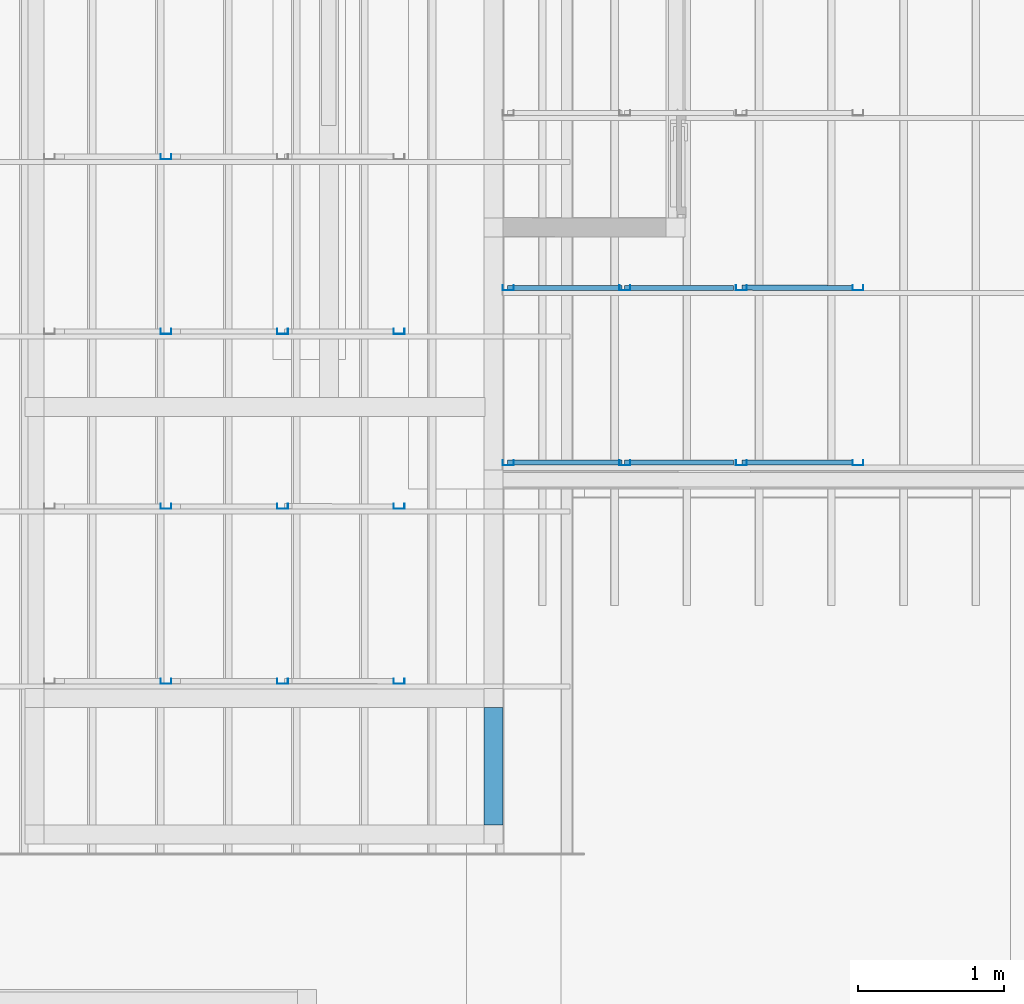
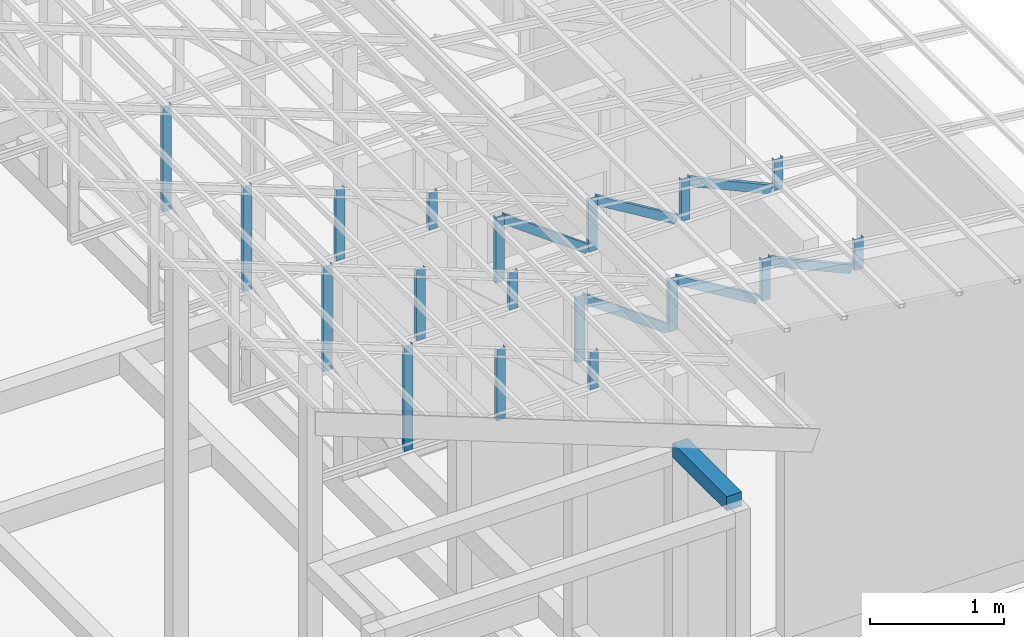
# One storey, part 16 of 22: 24 members, 1 beam, 2 elements without a shape of their own.
"""IFC4 building model written with IfcOpenShell, lengths in millimetres."""

from ifc_helpers import new_model, entity, si_unit, converted_unit, frame, origin_with_axes, origin_2d_with_axis, place, context, subcontext, project, spatial, rectangle, c_section, extrude, material, material_profile, profile_set, profile_usage, type_object, element, aggregate, save


model = new_model("IFC4")

# Units and contexts
model_context = context("Model", 3, precision=1e-05, world=origin_with_axes())
plan_context = context("Plan", 2, precision=1e-05, world=origin_2d_with_axis())
body_context = subcontext(model_context, "Body", "Model", "MODEL_VIEW")
ifc_project = project(units=[si_unit("VOLUMEUNIT", "CUBIC_METRE"), si_unit("LENGTHUNIT", "METRE", prefix="MILLI"), si_unit("AREAUNIT", "SQUARE_METRE"), converted_unit("PLANEANGLEUNIT", "degree", entity("IfcReal", 0.0174532925199433), si_unit("PLANEANGLEUNIT", "RADIAN"), dimensions=[0, 0, 0, 0, 0, 0, 0])], contexts=[model_context, plan_context])

# Site, building, storey
site_placement = place(None, origin_with_axes())
site = spatial("IfcSite", under=ifc_project, at=site_placement)
building_placement = place(site_placement, origin_with_axes())
building = spatial("IfcBuilding", under=site, at=building_placement, Name="2")
storey_placement = place(building_placement, frame((0.0, 0.0, 200.000002980232), z_axis=(0.0, 0.0, 1.0), x_axis=(1.0, 0.0, 0.0)))
storey = spatial("IfcBuildingStorey", under=building, at=storey_placement)

# Beam
ifc_material_1 = material(Name="Concrete")
ifc_material_profile_1 = material_profile(ifc_material_1, rectangle(XDim=130.000015258789, YDim=130.000015258789))
ifc_profile_set_1 = profile_set([ifc_material_profile_1])
ifc_profile_usage_1 = profile_usage(ifc_profile_set_1)
beam_type = type_object("IfcBeamType", Name="Ring", PredefinedType="BEAM", material=ifc_profile_set_1)
beam_placement = place(storey_placement, frame((-3999.99856948853, 4130.00440597534, 3270.00169456005), z_axis=(3.89414367418746e-07, 0.999999999999875, 3.13916473260139e-07), x_axis=(-0.999999999999924, 3.89414367418765e-07, -7.40532613008271e-09)))
element("IfcBeam", 1, at=beam_placement, inside=storey, type_object=beam_type, material=ifc_profile_usage_1, Name="Beam", PredefinedType="BEAM", context=body_context, shape_type="SweptSolid", body=[
    extrude(rectangle(XDim=130.000015258789, YDim=130.000015258789), origin_with_axes(), (0.0, 0.0, 1.0), 804.9960239384),
])

# Assembly, members
assembly_1_placement = place(storey_placement, frame((-1561.45393848419, 6600.0657081604, 3019.63977515697), z_axis=(0.0, 0.0, 1.0), x_axis=(1.0, 0.0, 0.0)))
assembly_1 = element("IfcElementAssembly", 2, at=assembly_1_placement, inside=storey, Name="K1")
ifc_material_2 = material(Name="STEEL")
ifc_material_profile_2 = material_profile(ifc_material_2, c_section(Depth=75.0, Width=35.0, WallThickness=1.0, Girth=1.0, kind="CURVE"))
ifc_profile_set_2 = profile_set([ifc_material_profile_2])
ifc_profile_usage_2 = profile_usage(ifc_profile_set_2, cardinal=9)
member_type = type_object("IfcMemberType", Name="C75", PredefinedType="CHORD", material=ifc_profile_set_2)
member_1_placement = place(assembly_1_placement, frame((-2299.51107501984, -1.06716156005859, 592.46301651001), z_axis=(-8.7422719730052e-08, 3.25841369885875e-07, -0.999999999999943), x_axis=(1.62920684942936e-07, 0.999999999999934, 3.25841369885871e-07)))
member_1 = element("IfcMember", 3, at=member_1_placement, type_object=member_type, material=ifc_profile_usage_2, Name="Member", context=body_context, shape_type="SweptSolid", body=[
    extrude(c_section(Depth=75.0, Width=35.0, WallThickness=1.0, Girth=1.0, kind="CURVE"), frame((17.5, -37.5, 0.0), z_axis=(0.0, 0.0, 1.0), x_axis=(1.0, 0.0, 0.0)), (0.0, 0.0, 1.0), 601.479041515268),
])
ifc_profile_usage_3 = profile_usage(ifc_profile_set_2, cardinal=9)
member_2_placement = place(assembly_1_placement, frame((-1499.51112270355, -1.06716156005859, 479.381561279297), z_axis=(-8.7422719730052e-08, 3.25841369885875e-07, -0.999999999999943), x_axis=(1.62920684942936e-07, 0.999999999999934, 3.25841369885871e-07)))
member_2 = element("IfcMember", 4, at=member_2_placement, type_object=member_type, material=ifc_profile_usage_3, Name="Member", context=body_context, shape_type="SweptSolid", body=[
    extrude(c_section(Depth=75.0, Width=35.0, WallThickness=1.0, Girth=1.0, kind="CURVE"), frame((17.5, -37.5, 0.0), z_axis=(0.0, 0.0, 1.0), x_axis=(1.0, 0.0, 0.0)), (0.0, 0.0, 1.0), 488.397843745656),
])
ifc_profile_usage_4 = profile_usage(ifc_profile_set_2, cardinal=9)
member_3_placement = place(assembly_1_placement, frame((-699.511170387268, -1.06716156005859, 377.824306488037), z_axis=(-8.7422719730052e-08, 3.25841369885875e-07, -0.999999999999943), x_axis=(1.62920684942936e-07, 0.999999999999934, 3.25841369885871e-07)))
member_3 = element("IfcMember", 5, at=member_3_placement, type_object=member_type, material=ifc_profile_usage_4, Name="Member", context=body_context, shape_type="SweptSolid", body=[
    extrude(c_section(Depth=75.0, Width=35.0, WallThickness=1.0, Girth=1.0, kind="CURVE"), frame((17.5, -37.5, 0.0), z_axis=(0.0, 0.0, 1.0), x_axis=(1.0, 0.0, 0.0)), (0.0, 0.0, 1.0), 386.840589191612),
])
ifc_profile_usage_5 = profile_usage(ifc_profile_set_2, cardinal=9)
member_4_placement = place(assembly_1_placement, frame((100.488781929016, -1.06716156005859, 276.402950286865), z_axis=(-8.7422719730052e-08, 3.25841369885875e-07, -0.999999999999943), x_axis=(1.62920684942936e-07, 0.999999999999934, 3.25841369885871e-07)))
member_4 = element("IfcMember", 6, at=member_4_placement, type_object=member_type, material=ifc_profile_usage_5, Name="Member", context=body_context, shape_type="SweptSolid", body=[
    extrude(c_section(Depth=75.0, Width=35.0, WallThickness=1.0, Girth=1.0, kind="CURVE"), frame((17.5, -37.5, 0.0), z_axis=(0.0, 0.0, 1.0), x_axis=(1.0, 0.0, 0.0)), (0.0, 0.0, 1.0), 285.419225275215),
])
ifc_profile_usage_6 = profile_usage(ifc_profile_set_2, cardinal=9)
member_5_placement = place(assembly_1_placement, frame((-702.355027198792, -0.0672340393066406, 368.052959442139), z_axis=(0.912206913056706, -0.00121979383816088, -0.409728031594797), x_axis=(0.00137145876901944, 0.999999056639273, 7.62981516029096e-05)))
member_5 = element("IfcMember", 7, at=member_5_placement, type_object=member_type, material=ifc_profile_usage_6, Name="Member", context=body_context, shape_type="SweptSolid", body=[
    extrude(c_section(Depth=75.0, Width=35.0, WallThickness=1.0, Girth=1.0, kind="CURVE"), frame((17.5, -37.5, 0.0), z_axis=(0.0, 0.0, 1.0), x_axis=(1.0, 0.0, 0.0)), (0.0, 0.0, 1.0), 791.494517196627),
])
ifc_profile_usage_7 = profile_usage(ifc_profile_set_2, cardinal=9)
member_6_placement = place(assembly_1_placement, frame((-1499.51112270355, -1.06716156005859, 479.381561279297), z_axis=(0.855801528545197, -4.23314648434558e-08, -0.517304304775924), x_axis=(7.5497901264043e-08, 0.999999999999996, 4.30689546249139e-08)))
member_6 = element("IfcMember", 8, at=member_6_placement, type_object=member_type, material=ifc_profile_usage_7, Name="Member", context=body_context, shape_type="SweptSolid", body=[
    extrude(c_section(Depth=75.0, Width=35.0, WallThickness=1.0, Girth=1.0, kind="CURVE"), frame((17.5, -37.5, 0.0), z_axis=(0.0, 0.0, 1.0), x_axis=(1.0, 0.0, 0.0)), (0.0, 0.0, 1.0), 826.976096113964),
])
ifc_profile_usage_8 = profile_usage(ifc_profile_set_2, cardinal=9)
member_7_placement = place(assembly_1_placement, frame((-2299.51107501984, -1.06716156005859, 592.46301651001), z_axis=(0.807471586940316, -1.26964538798404e-07, -0.589906464012789), x_axis=(7.54979012640426e-08, 0.999999999999991, -1.1188575399501e-07)))
member_7 = element("IfcMember", 9, at=member_7_placement, type_object=member_type, material=ifc_profile_usage_8, Name="Member", context=body_context, shape_type="SweptSolid", body=[
    extrude(c_section(Depth=75.0, Width=35.0, WallThickness=1.0, Girth=1.0, kind="CURVE"), frame((17.5, -37.5, 0.0), z_axis=(0.0, 0.0, 1.0), x_axis=(1.0, 0.0, 0.0)), (0.0, 0.0, 1.0), 921.685377112707),
])
ifc_profile_usage_9 = profile_usage(ifc_profile_set_2, cardinal=9)
member_8_placement = place(assembly_1_placement, frame((100.488781929016, 1198.93312454224, 276.402950286865), z_axis=(-8.7422719730052e-08, 3.25841369885875e-07, -0.999999999999943), x_axis=(1.62920684942936e-07, 0.999999999999934, 3.25841369885871e-07)))
member_8 = element("IfcMember", 10, at=member_8_placement, type_object=member_type, material=ifc_profile_usage_9, Name="Member", context=body_context, shape_type="SweptSolid", body=[
    extrude(c_section(Depth=75.0, Width=35.0, WallThickness=1.0, Girth=1.0, kind="CURVE"), frame((17.5, -37.5, 0.0), z_axis=(0.0, 0.0, 1.0), x_axis=(1.0, 0.0, 0.0)), (0.0, 0.0, 1.0), 285.419225275215),
])
ifc_profile_usage_10 = profile_usage(ifc_profile_set_2, cardinal=9)
member_9_placement = place(assembly_1_placement, frame((-702.355027198792, 1199.93257522583, 368.052959442139), z_axis=(0.912206913056706, -0.00121979383816088, -0.409728031594797), x_axis=(0.00137145876901944, 0.999999056639273, 7.62981516029096e-05)))
member_9 = element("IfcMember", 11, at=member_9_placement, type_object=member_type, material=ifc_profile_usage_10, Name="Member", context=body_context, shape_type="SweptSolid", body=[
    extrude(c_section(Depth=75.0, Width=35.0, WallThickness=1.0, Girth=1.0, kind="CURVE"), frame((17.5, -37.5, 0.0), z_axis=(0.0, 0.0, 1.0), x_axis=(1.0, 0.0, 0.0)), (0.0, 0.0, 1.0), 791.494517196627),
])
ifc_profile_usage_11 = profile_usage(ifc_profile_set_2, cardinal=9)
member_10_placement = place(assembly_1_placement, frame((-1499.51112270355, 1198.93312454224, 479.381561279297), z_axis=(0.855801528545197, -4.23314648434558e-08, -0.517304304775924), x_axis=(7.5497901264043e-08, 0.999999999999996, 4.30689546249139e-08)))
member_10 = element("IfcMember", 12, at=member_10_placement, type_object=member_type, material=ifc_profile_usage_11, Name="Member", context=body_context, shape_type="SweptSolid", body=[
    extrude(c_section(Depth=75.0, Width=35.0, WallThickness=1.0, Girth=1.0, kind="CURVE"), frame((17.5, -37.5, 0.0), z_axis=(0.0, 0.0, 1.0), x_axis=(1.0, 0.0, 0.0)), (0.0, 0.0, 1.0), 826.976096113964),
])
ifc_profile_usage_12 = profile_usage(ifc_profile_set_2, cardinal=9)
member_11_placement = place(assembly_1_placement, frame((-2299.51107501984, 1198.93312454224, 592.46301651001), z_axis=(-8.7422719730052e-08, 3.25841369885875e-07, -0.999999999999943), x_axis=(1.62920684942936e-07, 0.999999999999934, 3.25841369885871e-07)))
member_11 = element("IfcMember", 13, at=member_11_placement, type_object=member_type, material=ifc_profile_usage_12, Name="Member", context=body_context, shape_type="SweptSolid", body=[
    extrude(c_section(Depth=75.0, Width=35.0, WallThickness=1.0, Girth=1.0, kind="CURVE"), frame((17.5, -37.5, 0.0), z_axis=(0.0, 0.0, 1.0), x_axis=(1.0, 0.0, 0.0)), (0.0, 0.0, 1.0), 601.479041515268),
])
ifc_profile_usage_13 = profile_usage(ifc_profile_set_2, cardinal=9)
member_12_placement = place(assembly_1_placement, frame((-699.511170387268, 1198.93312454224, 377.824306488037), z_axis=(-8.7422719730052e-08, 3.25841369885875e-07, -0.999999999999943), x_axis=(1.62920684942936e-07, 0.999999999999934, 3.25841369885871e-07)))
member_12 = element("IfcMember", 14, at=member_12_placement, type_object=member_type, material=ifc_profile_usage_13, Name="Member", context=body_context, shape_type="SweptSolid", body=[
    extrude(c_section(Depth=75.0, Width=35.0, WallThickness=1.0, Girth=1.0, kind="CURVE"), frame((17.5, -37.5, 0.0), z_axis=(0.0, 0.0, 1.0), x_axis=(1.0, 0.0, 0.0)), (0.0, 0.0, 1.0), 386.840589191612),
])
ifc_profile_usage_14 = profile_usage(ifc_profile_set_2, cardinal=9)
member_13_placement = place(assembly_1_placement, frame((-1499.51112270355, 1198.93312454224, 479.381561279297), z_axis=(-8.7422719730052e-08, 3.25841369885875e-07, -0.999999999999943), x_axis=(1.62920684942936e-07, 0.999999999999934, 3.25841369885871e-07)))
member_13 = element("IfcMember", 15, at=member_13_placement, type_object=member_type, material=ifc_profile_usage_14, Name="Member", context=body_context, shape_type="SweptSolid", body=[
    extrude(c_section(Depth=75.0, Width=35.0, WallThickness=1.0, Girth=1.0, kind="CURVE"), frame((17.5, -37.5, 0.0), z_axis=(0.0, 0.0, 1.0), x_axis=(1.0, 0.0, 0.0)), (0.0, 0.0, 1.0), 488.397843745656),
])
ifc_profile_usage_15 = profile_usage(ifc_profile_set_2, cardinal=9)
member_14_placement = place(assembly_1_placement, frame((-2299.51107501984, 1198.93312454224, 592.46301651001), z_axis=(0.807471586940316, -1.26964538798404e-07, -0.589906464012789), x_axis=(7.54979012640426e-08, 0.999999999999991, -1.1188575399501e-07)))
member_14 = element("IfcMember", 16, at=member_14_placement, type_object=member_type, material=ifc_profile_usage_15, Name="Member", context=body_context, shape_type="SweptSolid", body=[
    extrude(c_section(Depth=75.0, Width=35.0, WallThickness=1.0, Girth=1.0, kind="CURVE"), frame((17.5, -37.5, 0.0), z_axis=(0.0, 0.0, 1.0), x_axis=(1.0, 0.0, 0.0)), (0.0, 0.0, 1.0), 921.685377112707),
])
aggregate(assembly_1, [member_1, member_2, member_3, member_4, member_5, member_6, member_7, member_8, member_9, member_10, member_11, member_12, member_13, member_14])

assembly_2_placement = place(storey_placement, frame((-3938.51041793823, 5099.00283813477, 3935.3459328413), z_axis=(0.0, 0.0, 1.0), x_axis=(1.0, 0.0, 0.0)))
assembly_2 = element("IfcElementAssembly", 17, at=assembly_2_placement, inside=storey, Name="2")
ifc_profile_usage_16 = profile_usage(ifc_profile_set_2, cardinal=1)
member_15_placement = place(assembly_2_placement, frame((-2346.510887146, 34.998893737793, 957.056522369385), z_axis=(-8.74227410463377e-08, -1.50995830949794e-07, -0.999999999999985), x_axis=(-3.13916473260159e-07, 0.999999999999939, -1.50995802528077e-07)))
member_15 = element("IfcMember", 18, at=member_15_placement, type_object=member_type, material=ifc_profile_usage_16, Name="Member", context=body_context, shape_type="SweptSolid", body=[
    extrude(c_section(Depth=75.0, Width=35.0, WallThickness=1.0, Girth=1.0, kind="CURVE"), frame((-17.5, 37.5, 0.0), z_axis=(0.0, 0.0, 1.0), x_axis=(1.0, 0.0, 0.0)), (0.0, 0.0, 1.0), 958.410273794281),
])
ifc_profile_usage_17 = profile_usage(ifc_profile_set_2, cardinal=1)
member_16_placement = place(assembly_2_placement, frame((-1546.51069641113, 34.998893737793, 648.419380187988), z_axis=(-8.74227410463377e-08, -1.50995830949794e-07, -0.999999999999985), x_axis=(-3.13916473260159e-07, 0.999999999999939, -1.50995802528077e-07)))
member_16 = element("IfcMember", 19, at=member_16_placement, type_object=member_type, material=ifc_profile_usage_17, Name="Member", context=body_context, shape_type="SweptSolid", body=[
    extrude(c_section(Depth=75.0, Width=35.0, WallThickness=1.0, Girth=1.0, kind="CURVE"), frame((-17.5, 37.5, 0.0), z_axis=(0.0, 0.0, 1.0), x_axis=(1.0, 0.0, 0.0)), (0.0, 0.0, 1.0), 649.773129888493),
])
ifc_profile_usage_18 = profile_usage(ifc_profile_set_2, cardinal=1)
member_17_placement = place(assembly_2_placement, frame((-746.51050567627, 34.998893737793, 339.939117431641), z_axis=(-8.74227410463377e-08, -1.50995830949794e-07, -0.999999999999985), x_axis=(-3.13916473260159e-07, 0.999999999999939, -1.50995802528077e-07)))
member_17 = element("IfcMember", 20, at=member_17_placement, type_object=member_type, material=ifc_profile_usage_18, Name="Member", context=body_context, shape_type="SweptSolid", body=[
    extrude(c_section(Depth=75.0, Width=35.0, WallThickness=1.0, Girth=1.0, kind="CURVE"), frame((-17.5, 37.5, 0.0), z_axis=(0.0, 0.0, 1.0), x_axis=(1.0, 0.0, 0.0)), (0.0, 0.0, 1.0), 341.292854350017),
])
ifc_profile_usage_19 = profile_usage(ifc_profile_set_2, cardinal=1)
member_18_placement = place(assembly_2_placement, frame((-2346.510887146, 1234.99870300293, 957.056522369385), z_axis=(-8.74227410463377e-08, -1.50995830949794e-07, -0.999999999999985), x_axis=(-3.13916473260159e-07, 0.999999999999939, -1.50995802528077e-07)))
member_18 = element("IfcMember", 21, at=member_18_placement, type_object=member_type, material=ifc_profile_usage_19, Name="Member", context=body_context, shape_type="SweptSolid", body=[
    extrude(c_section(Depth=75.0, Width=35.0, WallThickness=1.0, Girth=1.0, kind="CURVE"), frame((-17.5, 37.5, 0.0), z_axis=(0.0, 0.0, 1.0), x_axis=(1.0, 0.0, 0.0)), (0.0, 0.0, 1.0), 958.410273794281),
])
ifc_profile_usage_20 = profile_usage(ifc_profile_set_2, cardinal=1)
member_19_placement = place(assembly_2_placement, frame((-1546.51069641113, 1234.99870300293, 648.419380187988), z_axis=(-8.74227410463377e-08, -1.50995830949794e-07, -0.999999999999985), x_axis=(-3.13916473260159e-07, 0.999999999999939, -1.50995802528077e-07)))
member_19 = element("IfcMember", 22, at=member_19_placement, type_object=member_type, material=ifc_profile_usage_20, Name="Member", context=body_context, shape_type="SweptSolid", body=[
    extrude(c_section(Depth=75.0, Width=35.0, WallThickness=1.0, Girth=1.0, kind="CURVE"), frame((-17.5, 37.5, 0.0), z_axis=(0.0, 0.0, 1.0), x_axis=(1.0, 0.0, 0.0)), (0.0, 0.0, 1.0), 649.773129888493),
])
ifc_profile_usage_21 = profile_usage(ifc_profile_set_2, cardinal=1)
member_20_placement = place(assembly_2_placement, frame((-746.51050567627, 1234.99870300293, 339.939117431641), z_axis=(-8.74227410463377e-08, -1.50995830949794e-07, -0.999999999999985), x_axis=(-3.13916473260159e-07, 0.999999999999939, -1.50995802528077e-07)))
member_20 = element("IfcMember", 23, at=member_20_placement, type_object=member_type, material=ifc_profile_usage_21, Name="Member", context=body_context, shape_type="SweptSolid", body=[
    extrude(c_section(Depth=75.0, Width=35.0, WallThickness=1.0, Girth=1.0, kind="CURVE"), frame((-17.5, 37.5, 0.0), z_axis=(0.0, 0.0, 1.0), x_axis=(1.0, 0.0, 0.0)), (0.0, 0.0, 1.0), 341.292854350017),
])
ifc_profile_usage_22 = profile_usage(ifc_profile_set_2, cardinal=1)
member_21_placement = place(assembly_2_placement, frame((-2346.510887146, 2434.99851226807, 957.056522369385), z_axis=(-8.74227410463377e-08, -1.50995830949794e-07, -0.999999999999985), x_axis=(-3.13916473260159e-07, 0.999999999999939, -1.50995802528077e-07)))
member_21 = element("IfcMember", 24, at=member_21_placement, type_object=member_type, material=ifc_profile_usage_22, Name="Member", context=body_context, shape_type="SweptSolid", body=[
    extrude(c_section(Depth=75.0, Width=35.0, WallThickness=1.0, Girth=1.0, kind="CURVE"), frame((-17.5, 37.5, 0.0), z_axis=(0.0, 0.0, 1.0), x_axis=(1.0, 0.0, 0.0)), (0.0, 0.0, 1.0), 958.410273794281),
])
ifc_profile_usage_23 = profile_usage(ifc_profile_set_2, cardinal=1)
member_22_placement = place(assembly_2_placement, frame((-1546.51069641113, 2434.99851226807, 648.419380187988), z_axis=(-8.74227410463377e-08, -1.50995830949794e-07, -0.999999999999985), x_axis=(-3.13916473260159e-07, 0.999999999999939, -1.50995802528077e-07)))
member_22 = element("IfcMember", 25, at=member_22_placement, type_object=member_type, material=ifc_profile_usage_23, Name="Member", context=body_context, shape_type="SweptSolid", body=[
    extrude(c_section(Depth=75.0, Width=35.0, WallThickness=1.0, Girth=1.0, kind="CURVE"), frame((-17.5, 37.5, 0.0), z_axis=(0.0, 0.0, 1.0), x_axis=(1.0, 0.0, 0.0)), (0.0, 0.0, 1.0), 649.773129888493),
])
ifc_profile_usage_24 = profile_usage(ifc_profile_set_2, cardinal=1)
member_23_placement = place(assembly_2_placement, frame((-746.51050567627, 2434.99851226807, 339.939117431641), z_axis=(-8.74227410463377e-08, -1.50995830949794e-07, -0.999999999999985), x_axis=(-3.13916473260159e-07, 0.999999999999939, -1.50995802528077e-07)))
member_23 = element("IfcMember", 26, at=member_23_placement, type_object=member_type, material=ifc_profile_usage_24, Name="Member", context=body_context, shape_type="SweptSolid", body=[
    extrude(c_section(Depth=75.0, Width=35.0, WallThickness=1.0, Girth=1.0, kind="CURVE"), frame((-17.5, 37.5, 0.0), z_axis=(0.0, 0.0, 1.0), x_axis=(1.0, 0.0, 0.0)), (0.0, 0.0, 1.0), 341.292854350017),
])
ifc_profile_usage_25 = profile_usage(ifc_profile_set_2, cardinal=1)
member_24_placement = place(assembly_2_placement, frame((-2346.510887146, 3634.9983215332, 957.056522369385), z_axis=(-8.74227410463377e-08, -1.50995830949794e-07, -0.999999999999985), x_axis=(-3.13916473260159e-07, 0.999999999999939, -1.50995802528077e-07)))
member_24 = element("IfcMember", 27, at=member_24_placement, type_object=member_type, material=ifc_profile_usage_25, Name="Member", context=body_context, shape_type="SweptSolid", body=[
    extrude(c_section(Depth=75.0, Width=35.0, WallThickness=1.0, Girth=1.0, kind="CURVE"), frame((-17.5, 37.5, 0.0), z_axis=(0.0, 0.0, 1.0), x_axis=(1.0, 0.0, 0.0)), (0.0, 0.0, 1.0), 958.410273794281),
])
aggregate(assembly_2, [member_15, member_16, member_17, member_18, member_19, member_20, member_21, member_22, member_23, member_24])

save(model, "model.ifc")
